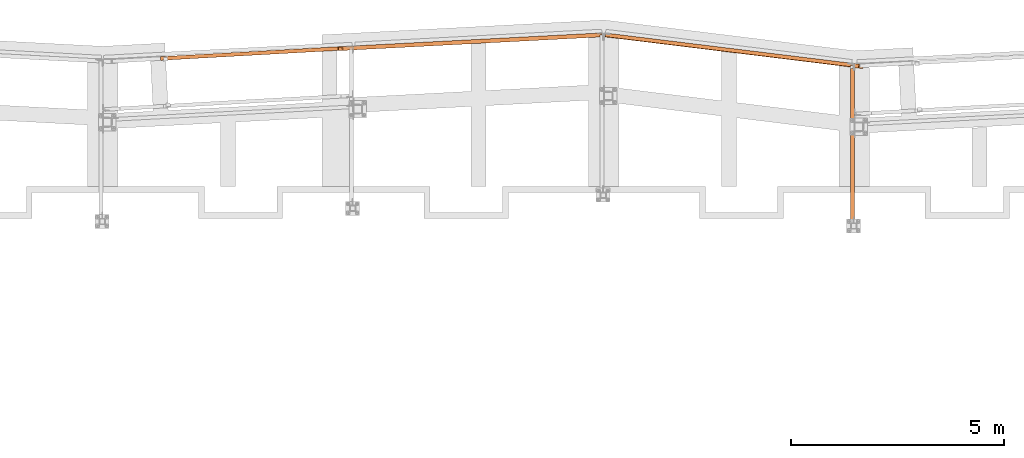
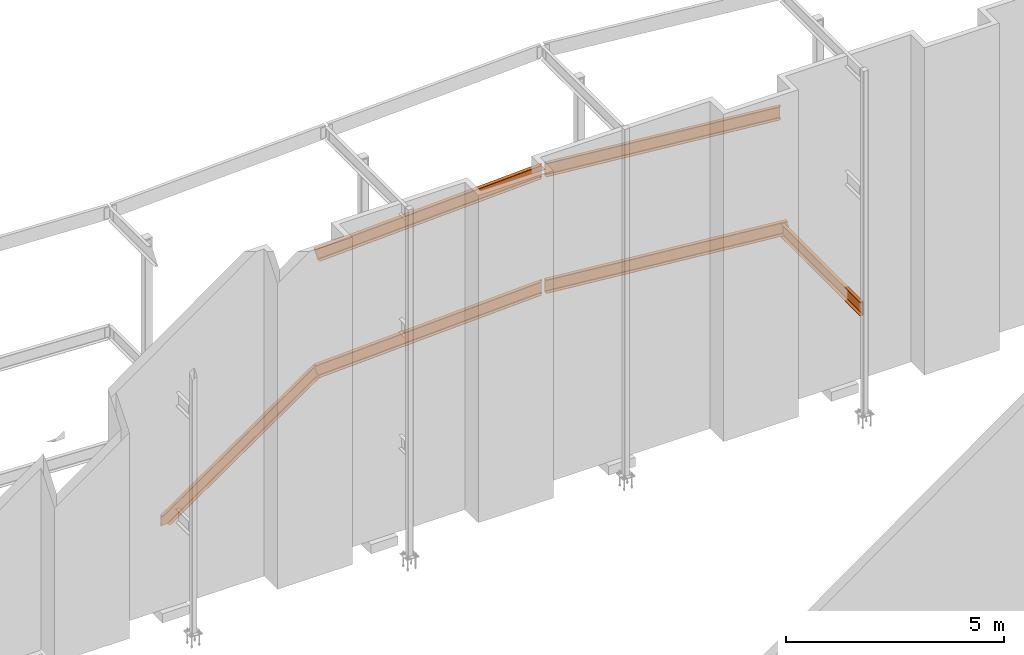
# One storey, part 17 of 89: 6 proxies.
"""IFC4 building model written with IfcOpenShell, lengths in feet."""

from ifc_helpers import new_model, entity, si_unit, converted_unit, derived_unit, direction, frame, origin, place, context, subcontext, project, spatial, faceted_brep, source, transform, mapped, material, constituent, constituent_set, type_object, type_shapes, element, save


model = new_model("IFC4")

# Units and contexts
model_context = context("Model", 3, precision=0.0001, world=origin(), true_north=direction((6.12303176911189e-17, 1.0)))
body_context = subcontext(model_context, "Body", "Model", "MODEL_VIEW")
ifc_project = project(units=[converted_unit("LENGTHUNIT", "FOOT", entity("IfcRatioMeasure", 0.3048), si_unit("LENGTHUNIT", "METRE"), dimensions=[1, 0, 0, 0, 0, 0, 0]), converted_unit("AREAUNIT", "SQUARE FOOT", entity("IfcRatioMeasure", 0.09290304), si_unit("AREAUNIT", "SQUARE_METRE"), dimensions=[2, 0, 0, 0, 0, 0, 0]), converted_unit("VOLUMEUNIT", "CUBIC FOOT", entity("IfcRatioMeasure", 0.028316846592), si_unit("VOLUMEUNIT", "CUBIC_METRE"), dimensions=[3, 0, 0, 0, 0, 0, 0]), si_unit("PLANEANGLEUNIT", "RADIAN"), si_unit("MASSUNIT", "GRAM", prefix="KILO"), derived_unit("MASSDENSITYUNIT", [(si_unit("MASSUNIT", "GRAM", prefix="KILO"), 1), (si_unit("LENGTHUNIT", "METRE"), -3)]), derived_unit("MOMENTOFINERTIAUNIT", [(si_unit("LENGTHUNIT", "METRE"), 4)]), si_unit("TIMEUNIT", "SECOND"), si_unit("FREQUENCYUNIT", "HERTZ"), si_unit("THERMODYNAMICTEMPERATUREUNIT", "DEGREE_CELSIUS"), derived_unit("THERMALTRANSMITTANCEUNIT", [(si_unit("MASSUNIT", "GRAM", prefix="KILO"), 1), (si_unit("THERMODYNAMICTEMPERATUREUNIT", "KELVIN"), -1), (si_unit("TIMEUNIT", "SECOND"), -3)]), derived_unit("VOLUMETRICFLOWRATEUNIT", [(si_unit("LENGTHUNIT", "METRE"), 3), (si_unit("TIMEUNIT", "SECOND"), -1)]), si_unit("ELECTRICCURRENTUNIT", "AMPERE"), si_unit("ELECTRICVOLTAGEUNIT", "VOLT"), si_unit("POWERUNIT", "WATT"), si_unit("FORCEUNIT", "NEWTON"), si_unit("ILLUMINANCEUNIT", "LUX"), si_unit("LUMINOUSFLUXUNIT", "LUMEN"), si_unit("LUMINOUSINTENSITYUNIT", "CANDELA"), derived_unit("USERDEFINED", [(si_unit("MASSUNIT", "GRAM", prefix="KILO"), -1), (si_unit("LENGTHUNIT", "METRE"), -2), (si_unit("TIMEUNIT", "SECOND"), 3), (si_unit("LUMINOUSFLUXUNIT", "LUMEN"), 1)]), derived_unit("LINEARVELOCITYUNIT", [(si_unit("LENGTHUNIT", "METRE"), 1), (si_unit("TIMEUNIT", "SECOND"), -1)]), si_unit("PRESSUREUNIT", "PASCAL"), derived_unit("USERDEFINED", [(si_unit("LENGTHUNIT", "METRE"), -2), (si_unit("MASSUNIT", "GRAM", prefix="KILO"), 1), (si_unit("TIMEUNIT", "SECOND"), -2)]), derived_unit("LINEARFORCEUNIT", [(si_unit("MASSUNIT", "GRAM", prefix="KILO"), 1), (si_unit("LENGTHUNIT", "METRE"), 1), (si_unit("TIMEUNIT", "SECOND"), -2), (si_unit("LENGTHUNIT", "METRE"), -1)]), derived_unit("PLANARFORCEUNIT", [(si_unit("MASSUNIT", "GRAM", prefix="KILO"), 1), (si_unit("LENGTHUNIT", "METRE"), 1), (si_unit("TIMEUNIT", "SECOND"), -2), (si_unit("LENGTHUNIT", "METRE"), -2)])], contexts=[model_context])

# Site, building, storey
site_placement = place(None, origin())
site = spatial("IfcSite", under=ifc_project, at=site_placement, CompositionType="ELEMENT")
building_placement = place(site_placement, frame((-472.238160486, -49.138065117, 0.0)))
building = spatial("IfcBuilding", under=site, at=building_placement, CompositionType="ELEMENT")
storey_placement = place(building_placement, origin())
storey = spatial("IfcBuildingStorey", under=building, at=storey_placement, Name="Level 1", CompositionType="ELEMENT", Elevation=0.0)

# Proxies
ifc_material_1 = material(Name="Color 7720", Category="Materials")
ifc_material_2 = material()
ifc_constituent_1 = constituent(ifc_material_2)
ifc_constituent_2 = constituent(ifc_material_1, Name="Color 7720", Category="Materials")
ifc_constituent_set_1 = constituent_set(constituents=[ifc_constituent_1, ifc_constituent_2])
building_element_proxy_type_1 = type_object("IfcBuildingElementProxyType", Name="21B1", PredefinedType="NOTDEFINED", material=ifc_constituent_set_1)
shared_shape_1 = source(origin(), body_context, "Body", "Brep", [
    faceted_brep([(0.0377794964555278, 2.75073335405659, 1.25), (0.0377794964555278, 2.75073335405659, 0.0), (0.0, 2.44304404704769, 0.0), (0.0, 2.44304404704769, 0.0333062789934004), (0.0251267470594598, 2.64768497970852, 0.0676680457191203), (0.0272486596628596, 2.66496657104051, 0.0738437414016904), (0.0289818227031446, 2.67908205125684, 0.0856354543123796), (0.0301143991183039, 2.68830614593799, 0.10160193411237), (0.0305079589656998, 2.69151143367526, 0.11979166666667), (0.0305079589656998, 2.69151143367526, 1.13020833333333), (0.0301143991183039, 2.68830614593799, 1.14839806588763), (0.0289818227031446, 2.67908205125684, 1.16436454568762), (0.0272486596628596, 2.66496657104051, 1.17615625859831), (0.0251267470594598, 2.64768497970852, 1.18233195428088), (0.0, 2.44304404704769, 1.2166937210066), (0.0, 2.44304404704769, 1.25), (19.5543690065045, 0.0420694348507595, 1.24999999999986), (19.5634983388827, 0.0409484937833895, 1.21669372100646), (19.5980437300844, 0.244432962358815, 1.18233195428074), (19.6018584159503, 0.261506707269177, 1.17615625859818), (19.6068237162849, 0.275225330927015, 1.16436454568747), (19.61233274379, 0.283912064982815, 1.1483980658875), (19.6177121537347, 0.286505167305222, 1.1302083333332), (19.8946698286601, 0.252499040800672, 0.119791666666796), (19.89926211891, 0.248681567648418, 0.101601934112518), (19.9025059935848, 0.23892011234193, 0.0856354543125466), (19.9040049678388, 0.224407775567101, 0.0738437414018609), (19.9035758284979, 0.206918337813363, 0.0676680457192891), (19.8878677255806, 0.00112094106725635, 0.0333062789935603), (19.8969970579588, 0.0, 0.0), (19.9347765544144, 0.307689307008786, 0.0), (19.5921485029601, 0.349758741859659, 1.24999999999986)], [[[0, 1, 2, 3, 4, 5, 6, 7, 8, 9, 10, 11, 12, 13, 14, 15]], [[16, 17, 18, 19, 20, 21, 22, 23, 24, 25, 26, 27, 28, 29, 30, 31]], [[30, 1, 0, 31]], [[29, 2, 1, 30]], [[28, 3, 2, 29]], [[27, 4, 3, 28]], [[26, 5, 4, 27]], [[25, 6, 5, 26]], [[24, 7, 6, 25]], [[23, 8, 7, 24]], [[22, 9, 8, 23]], [[21, 10, 9, 22]], [[20, 11, 10, 21]], [[19, 12, 11, 20]], [[18, 13, 12, 19]], [[17, 14, 13, 18]], [[16, 15, 14, 17]], [[31, 0, 15, 16]]]),
])
type_shapes(building_element_proxy_type_1, [shared_shape_1])
proxy_1_placement = place(building_placement, frame((269.262655882732, 1017.10742242747, 8.35416666666667)))
element("IfcBuildingElementProxy", 1, at=proxy_1_placement, inside=storey, type_object=building_element_proxy_type_1, material=ifc_material_1, Name="21B1:21B1", ObjectType="21B1:21B1", PredefinedType="NOTDEFINED", context=body_context, shape_type="MappedRepresentation", body=[
    mapped(shared_shape_1, transform((0.0, 0.0, 0.0), scale=1.0)),
])
ifc_constituent_3 = constituent(ifc_material_2)
ifc_constituent_4 = constituent(ifc_material_1, Name="Color 7720", Category="Materials")
ifc_constituent_set_2 = constituent_set(constituents=[ifc_constituent_3, ifc_constituent_4])
building_element_proxy_type_2 = type_object("IfcBuildingElementProxyType", Name="22B1", PredefinedType="NOTDEFINED", material=ifc_constituent_set_2)
shared_shape_2 = source(origin(), body_context, "Body", "Brep", [
    faceted_brep([(0.0, 0.309575155773928, 1.25000000000001), (0.357523018910911, 0.328312143237667, 0.0), (0.373747165346231, 0.0187369874637398, 0.0), (0.364220956214695, 0.0182377399981988, 0.0333062789934182), (0.343602348434359, 0.223617862109791, 0.0676680457191399), (0.340924744883978, 0.240912802348703, 0.0738437414017064), (0.336807802828474, 0.254938044365076, 0.0856354543123956), (0.331754718383394, 0.263979343166739, 0.10160193411239), (0.326383108321096, 0.266931619698767, 0.119791666666686), (0.0373853347014972, 0.2517858881655, 1.13020833333334), (0.0323517478101962, 0.248288298368379, 1.14839806588764), (0.0282714177601235, 0.238768337595616, 1.16436454568763), (0.0256430657389046, 0.224389589695988, 1.17615625859832), (0.0247879439063752, 0.206909507165051, 1.18233195428089), (0.0257503555669132, 0.000499247465540975, 1.2166937210066), (0.016224146435377, 0.0, 1.25000000000001), (20.3463952666531, 1.22985108098965, 0.0), (20.338762939701, 1.37548455480794, 0.0), (20.338762939701, 1.37548455480794, 1.25), (20.3463952666531, 1.22985108098965, 1.25), (20.3463952666531, 1.22985108098965, 1.18933355874539), (20.3441965764159, 1.27180458993962, 1.18233195428088), (20.343285335557, 1.2891921013246, 1.17615625859831), (20.3425410405399, 1.30339409628266, 1.16436454568762), (20.3420546633424, 1.31267472606976, 1.14839806588763), (20.3418856517569, 1.31589965923422, 1.13020833333333), (20.3418856517569, 1.31589965923422, 0.11979166666667), (20.3420546633424, 1.31267472606976, 0.10160193411237), (20.3425410405399, 1.30339409628266, 0.0856354543123796), (20.343285335557, 1.2891921013246, 0.0738437414016904), (20.3441965764159, 1.27180458993962, 0.0676680457191203), (20.3463952666531, 1.22985108098965, 0.0606664412546092), (20.2162116682723, 1.21985240890331, 0.0), (20.2031852629111, 1.21012513065352, 0.0), (20.1948729018438, 1.19615330785678, 0.0), (20.1925400666913, 1.18006402387846, 0.0), (20.198951221331, 1.05773190587115, 0.0), (20.2319689657958, 1.22385425267009, 0.0), (20.198951221331, 1.05773190587115, 0.0333062789934004), (20.1948729018436, 1.1961533078611, 0.0563796692854748), (20.2031852629109, 1.21012513065784, 0.0586325310785618), (20.2162116682721, 1.21985240890763, 0.0601378452028776), (20.2319689657956, 1.22385425267441, 0.0606664412286193), (20.192540066691, 1.18006402388278, 0.0537222376092839), (20.2162116682723, 1.21985240890331, 1.18986215477137), (20.2031852629111, 1.21012513065352, 1.19136746889581), (20.1948729018438, 1.19615330785678, 1.19362033068901), (20.1925400666913, 1.18006402387846, 1.19627776236529), (20.198951221331, 1.05773190587126, 1.21669372100739), (20.2319689657958, 1.22385425267009, 1.1893335587455), (20.198951221331, 1.05773190587115, 1.25), (20.1948729018438, 1.19615330785678, 1.25), (20.2031852629111, 1.21012513065352, 1.25), (20.2162116682723, 1.21985240890331, 1.25), (20.2319689657958, 1.22385425267009, 1.25), (20.1925400666913, 1.18006402387846, 1.25)], [[[0, 1, 2, 3, 4, 5, 6, 7, 8, 9, 10, 11, 12, 13, 14, 15]], [[16, 17, 18, 19, 20, 21, 22, 23, 24, 25, 26, 27, 28, 29, 30, 31]], [[17, 1, 0, 18]], [[32, 33, 34, 35, 36, 2, 1, 17, 16, 37]], [[38, 3, 2, 36]], [[39, 40, 41, 42, 31, 30, 4, 3, 38, 43]], [[29, 5, 4, 30]], [[28, 6, 5, 29]], [[27, 7, 6, 28]], [[26, 8, 7, 27]], [[25, 9, 8, 26]], [[24, 10, 9, 25]], [[23, 11, 10, 24]], [[22, 12, 11, 23]], [[21, 13, 12, 22]], [[44, 45, 46, 47, 48, 14, 13, 21, 20, 49]], [[50, 15, 14, 48]], [[51, 52, 53, 54, 19, 18, 0, 15, 50, 55]], [[19, 54, 49, 20]], [[53, 44, 49, 54]], [[52, 45, 44, 53]], [[51, 46, 45, 52]], [[55, 47, 46, 51]], [[48, 47, 55, 50]], [[42, 37, 16, 31]], [[32, 37, 42, 41]], [[33, 32, 41, 40]], [[34, 33, 40, 39]], [[35, 34, 39, 43]], [[35, 43, 38, 36]]]),
])
type_shapes(building_element_proxy_type_2, [shared_shape_2])
proxy_2_placement = place(building_placement, frame((248.665914336964, 1018.49083804157, 8.35416666666667)))
element("IfcBuildingElementProxy", 2, at=proxy_2_placement, inside=storey, type_object=building_element_proxy_type_2, material=ifc_material_1, Name="22B1:22B1", ObjectType="22B1:22B1", PredefinedType="NOTDEFINED", context=body_context, shape_type="MappedRepresentation", body=[
    mapped(shared_shape_2, transform((0.0, 0.0, 0.0), scale=1.0)),
])
ifc_constituent_5 = constituent(ifc_material_2)
ifc_constituent_6 = constituent(ifc_material_1, Name="Color 7720", Category="Materials")
ifc_constituent_set_3 = constituent_set(constituents=[ifc_constituent_5, ifc_constituent_6])
building_element_proxy_type_3 = type_object("IfcBuildingElementProxyType", Name="16B1", PredefinedType="NOTDEFINED", material=ifc_constituent_set_3)
shared_shape_3 = source(origin(), body_context, "Body", "Brep", [
    faceted_brep([(0.0345296472984273, 2.6011820874744, 1.25), (0.0345296472984273, 2.6011820874744, 0.0), (0.0, 2.3199606778428, 0.0), (0.0, 2.3199606778428, 0.033334055807881), (0.0250827848585686, 2.52424356710685, 0.0676357025785492), (0.0272060141263637, 2.54153588181021, 0.0738152303316895), (0.028940252608777, 2.55566012079942, 0.0856142600983709), (0.0300735317970293, 2.56488993910807, 0.101590647231951), (0.030467335851597, 2.56809721575314, 0.119791666666671), (0.030467335851597, 2.56809721575314, 1.13020833333333), (0.0300735317970293, 2.56488993910807, 1.14840935276805), (0.028940252608777, 2.55566012079942, 1.16438573990164), (0.0272060141263637, 2.54153588181021, 1.17618476966831), (0.0250827848585686, 2.52424356710685, 1.18236429742145), (0.0, 2.3199606778428, 1.21666594419212), (0.0, 2.3199606778428, 1.25), (19.0600584689071, 0.0657378988789787, 0.0), (19.0841784431227, 0.262179324724571, 0.0), (19.0841784431227, 0.262179324724571, 1.25), (19.0600584689071, 0.0657378988789787, 1.25), (19.0600584689071, 0.0657378988789787, 1.20243032677195), (19.0747315806829, 0.185240804357022, 1.18236429742145), (19.0768548099507, 0.202533119060263, 1.17618476966831), (19.0785890484331, 0.216657358049474, 1.16438573990164), (19.0797223276214, 0.225887176358356, 1.14840935276805), (19.0801161316759, 0.229094453003199, 1.13020833333333), (19.0801161316759, 0.229094453003199, 0.119791666666671), (19.0797223276214, 0.225887176358356, 0.101590647231951), (19.0785890484331, 0.216657358049474, 0.0856142600983709), (19.0768548099507, 0.202533119060263, 0.0738152303316895), (19.0747315806829, 0.185240804357022, 0.0676357025785492), (19.0600584689071, 0.0657378988789787, 0.0475696732280504), (18.9301164007198, 0.0784972737093312, 0.0), (18.9155987715845, 0.0711797862259118, 0.0), (18.9049865123923, 0.0588636531633711, 0.0), (18.8998952434047, 0.043423894134321, 0.0), (18.8945634596307, 0.0, 0.0), (18.946329222365, 0.0797020944773976, 0.0), (18.8945634596307, 0.0, 0.033334055807881), (18.9049865123923, 0.0588636531639395, 0.0432829012814437), (18.9155987715846, 0.0711797862264802, 0.0455357630745894), (18.9301164007198, 0.0784972737098997, 0.0470410771989549), (18.946329222365, 0.0797020944779661, 0.0475696732248103), (18.8998952434047, 0.0434238941348895, 0.0406254696052635), (18.9301164007198, 0.0784972737094449, 1.20295892279827), (18.9155987715845, 0.0711797862260255, 1.20446423692263), (18.9049865123923, 0.0588636531634847, 1.20671709871575), (18.8998952434047, 0.0434238941344347, 1.2093745303919), (18.8945634596307, 0.0, 1.2166659441924), (18.946329222365, 0.0797020944775113, 1.20243032677241), (18.8945634596307, 0.0, 1.25), (18.9049865123923, 0.0588636531633711, 1.25), (18.9155987715845, 0.0711797862259118, 1.25), (18.9301164007198, 0.0784972737093312, 1.25), (18.946329222365, 0.0797020944773976, 1.25), (18.8998952434047, 0.043423894134321, 1.25)], [[[0, 1, 2, 3, 4, 5, 6, 7, 8, 9, 10, 11, 12, 13, 14, 15]], [[16, 17, 18, 19, 20, 21, 22, 23, 24, 25, 26, 27, 28, 29, 30, 31]], [[17, 1, 0, 18]], [[32, 33, 34, 35, 36, 2, 1, 17, 16, 37]], [[38, 3, 2, 36]], [[39, 40, 41, 42, 31, 30, 4, 3, 38, 43]], [[29, 5, 4, 30]], [[28, 6, 5, 29]], [[27, 7, 6, 28]], [[26, 8, 7, 27]], [[25, 9, 8, 26]], [[24, 10, 9, 25]], [[23, 11, 10, 24]], [[22, 12, 11, 23]], [[21, 13, 12, 22]], [[44, 45, 46, 47, 48, 14, 13, 21, 20, 49]], [[50, 15, 14, 48]], [[51, 52, 53, 54, 19, 18, 0, 15, 50, 55]], [[19, 54, 49, 20]], [[53, 44, 49, 54]], [[52, 45, 44, 53]], [[51, 46, 45, 52]], [[55, 47, 46, 51]], [[48, 47, 55, 50]], [[42, 37, 16, 31]], [[32, 37, 42, 41]], [[33, 32, 41, 40]], [[34, 33, 40, 39]], [[35, 34, 39, 43]], [[35, 43, 38, 36]]]),
])
type_shapes(building_element_proxy_type_3, [shared_shape_3])
proxy_3_placement = place(building_placement, frame((269.266544310737, 1017.25731477227, 19.0208333333333)))
element("IfcBuildingElementProxy", 3, at=proxy_3_placement, inside=storey, type_object=building_element_proxy_type_3, material=ifc_material_1, Name="16B1:16B1", ObjectType="16B1:16B1", PredefinedType="NOTDEFINED", context=body_context, shape_type="MappedRepresentation", body=[
    mapped(shared_shape_3, transform((0.0, 0.0, 0.0), scale=1.0)),
])
ifc_constituent_7 = constituent(ifc_material_2)
ifc_constituent_8 = constituent(ifc_material_1, Name="Color 7720", Category="Materials")
ifc_constituent_set_4 = constituent_set(constituents=[ifc_constituent_7, ifc_constituent_8])
building_element_proxy_type_4 = type_object("IfcBuildingElementProxyType", Name="30B1", PredefinedType="NOTDEFINED", material=ifc_constituent_set_4)
shared_shape_4 = source(origin(), body_context, "Body", "Brep", [
    faceted_brep([(0.0, 0.309575155773928, 1.25), (0.349557129762729, 0.327894668677345, 0.0), (0.365781276198021, 0.0183195129034175, 0.0), (0.356467318367606, 0.0178313890572781, 0.0333062789933933), (0.336067688207038, 0.223222987299664, 0.0676680457191239), (0.333429440582421, 0.240519990095095, 0.0738437414016886), (0.329387643709254, 0.25454917030379, 0.0856354543123743), (0.324436309030716, 0.263595801584756, 0.101601934112363), (0.31918061688296, 0.266554153116999, 0.119791666666671), (0.0366219369913949, 0.251745880186945, 1.13020833333333), (0.0317042680146358, 0.248254365390039, 1.14839806588762), (0.0277256877310776, 0.238739737096694, 1.16436454568763), (0.0251724808921665, 0.224364927389388, 1.1761562585983), (0.02435671498543, 0.206886907414969, 1.18233195428089), (0.0255381042656779, 0.000488123846253075, 1.2166937210066), (0.0162241464352633, 0.0, 1.24999999999999), (20.3463952666532, 1.22985108098953, 0.0), (20.338762939701, 1.37548455480783, 0.0), (20.338762939701, 1.37548455480783, 1.25), (20.3463952666532, 1.22985108098953, 1.25), (20.3463952666532, 1.22985108098953, 1.18933355874539), (20.344196576416, 1.27180458993951, 1.18233195428088), (20.343285335557, 1.28919210132449, 1.17615625859831), (20.3425410405399, 1.30339409628255, 1.16436454568762), (20.3420546633424, 1.31267472606964, 1.14839806588763), (20.3418856517569, 1.31589965923411, 1.13020833333333), (20.3418856517569, 1.31589965923411, 0.119791666666671), (20.3420546633424, 1.31267472606964, 0.10160193411237), (20.3425410405399, 1.30339409628255, 0.0856354543123814), (20.343285335557, 1.28919210132449, 0.0738437414016886), (20.344196576416, 1.27180458993951, 0.0676680457191203), (20.3463952666532, 1.22985108098953, 0.060666441254611), (20.2058092772852, 1.21930724269214, 0.0), (20.192782871924, 1.2095799644427, 0.0), (20.1844705108568, 1.19560814164572, 0.0), (20.1821376757042, 1.17951885766763, 0.0), (20.1885488303439, 1.0571867396601, 0.0), (20.2215665748087, 1.22330908645915, 0.0), (20.1885488303439, 1.0571867396601, 0.0333062789934004), (20.1844705108569, 1.19560814164208, 0.0563796693330865), (20.1927828719242, 1.20957996443906, 0.0586325311263209), (20.2058092772854, 1.2193072426885, 0.0601378452507468), (20.2215665748089, 1.22330908645552, 0.060666441276723), (20.1821376757044, 1.17951885766399, 0.0537222376568991), (20.2058092772852, 1.21930724269214, 1.18986215477156), (20.192782871924, 1.2095799644427, 1.19136746889583), (20.1844705108568, 1.19560814164572, 1.1936203306889), (20.1821376757042, 1.17951885766763, 1.19627776236494), (20.1885488303439, 1.05718673965987, 1.21669372100557), (20.2215665748087, 1.22330908645915, 1.1893335587457), (20.1885488303439, 1.0571867396601, 1.25), (20.1844705108568, 1.19560814164572, 1.25), (20.192782871924, 1.2095799644427, 1.25), (20.2058092772852, 1.21930724269214, 1.25), (20.2215665748087, 1.22330908645915, 1.25), (20.1821376757042, 1.17951885766763, 1.25)], [[[0, 1, 2, 3, 4, 5, 6, 7, 8, 9, 10, 11, 12, 13, 14, 15]], [[16, 17, 18, 19, 20, 21, 22, 23, 24, 25, 26, 27, 28, 29, 30, 31]], [[17, 1, 0, 18]], [[32, 33, 34, 35, 36, 2, 1, 17, 16, 37]], [[38, 3, 2, 36]], [[39, 40, 41, 42, 31, 30, 4, 3, 38, 43]], [[29, 5, 4, 30]], [[28, 6, 5, 29]], [[27, 7, 6, 28]], [[26, 8, 7, 27]], [[25, 9, 8, 26]], [[24, 10, 9, 25]], [[23, 11, 10, 24]], [[22, 12, 11, 23]], [[21, 13, 12, 22]], [[44, 45, 46, 47, 48, 14, 13, 21, 20, 49]], [[50, 15, 14, 48]], [[51, 52, 53, 54, 19, 18, 0, 15, 50, 55]], [[19, 54, 49, 20]], [[53, 44, 49, 54]], [[52, 45, 44, 53]], [[51, 46, 45, 52]], [[55, 47, 46, 51]], [[48, 47, 55, 50]], [[42, 37, 16, 31]], [[32, 37, 42, 41]], [[33, 32, 41, 40]], [[34, 33, 40, 39]], [[35, 34, 39, 43]], [[35, 43, 38, 36]]]),
])
type_shapes(building_element_proxy_type_4, [shared_shape_4])
proxy_4_placement = place(building_placement, frame((248.666666666667, 1018.49106536893, 19.0208333333333)))
element("IfcBuildingElementProxy", 4, at=proxy_4_placement, inside=storey, type_object=building_element_proxy_type_4, material=ifc_material_1, Name="30B1:30B1", ObjectType="30B1:30B1", PredefinedType="NOTDEFINED", context=body_context, shape_type="MappedRepresentation", body=[
    mapped(shared_shape_4, transform((0.0, 0.0, 0.0), scale=1.0)),
])
ifc_constituent_9 = constituent(ifc_material_2)
ifc_constituent_10 = constituent(ifc_material_1, Name="Color 7720", Category="Materials")
ifc_constituent_set_5 = constituent_set(constituents=[ifc_constituent_9, ifc_constituent_10])
building_element_proxy_type_5 = type_object("IfcBuildingElementProxyType", Name="c775", PredefinedType="NOTDEFINED", material=ifc_constituent_set_5)
shared_shape_5 = source(origin(), body_context, "Body", "Brep", [
    faceted_brep([(0.0, 0.0, 1.25), (0.0, 0.0, 1.21666594419212), (0.205817018106814, 0.0, 1.18236429742145), (0.22323919507528, 0.0, 1.17618476966831), (0.237469504634078, 0.0, 1.16438573990164), (0.246768637267337, 0.0, 1.14840935276805), (0.25, 0.0, 1.13020833333334), (0.25, 0.0, 0.119791666666673), (0.246768637267337, 0.0, 0.101590647231953), (0.237469504634078, 0.0, 0.0856142600983727), (0.22323919507528, 0.0, 0.073815230331693), (0.205817018106814, 0.0, 0.0676357025785528), (0.0, 0.0, 0.0333340558078827), (0.0, 0.0, 0.0), (0.28333333333336, 0.0, 0.0), (0.28333333333336, 0.0, 1.25), (0.25, 12.0372040033701, 1.125), (0.28333333333336, 12.0372040033701, 1.125), (0.28333333333336, 12.0372040033701, 0.125000000000004), (0.25, 12.0372040033701, 0.125000000000004), (0.0, 11.8913706700368, 1.21666594419212), (0.0, 11.8913706700368, 1.25), (0.205817018106814, 11.8913706700368, 1.18236429742145), (0.208250000000021, 11.8913706700368, 1.18150133528077), (0.22323919507528, 11.8913706700368, 1.17618476966832), (0.234718575567058, 11.8913706700368, 1.16666666666667), (0.237469504634078, 11.8918243745794, 1.16438573990162), (0.245422827132927, 11.8945423561822, 1.15072152365148), (0.246768637267337, 11.8960872993737, 1.14840935276807), (0.248758027692929, 11.9035745541541, 1.13720388411723), (0.249999999999943, 11.9140441357703, 1.13020833333334), (0.250000000000057, 11.9170921936882, 0.121828313854644), (0.250000000000057, 11.9140441357703, 0.119791666666673), (0.250000000000057, 11.9170921936882, 1.12817168614537), (0.250000000000057, 11.9330373367035, 1.125), (0.250000000000057, 11.9330373367035, 0.125000000000004), (0.248758027692986, 11.9035745541541, 0.11279611588277), (0.246768637267337, 11.8960872993737, 0.101590647231946), (0.245422827132927, 11.8945423561822, 0.099278476348525), (0.237469504634078, 11.8918243745794, 0.0856142600983567), (0.234718575567058, 11.8913706700368, 0.0833333333332948), (0.22323919507528, 11.8913706700368, 0.0738152303316735), (0.205817018106814, 11.8913706700368, 0.0676357025785528), (0.208250000000021, 11.8913706700368, 0.0684986647192289), (0.0, 11.8913706700368, 0.0333340558078827), (0.0, 11.8913706700368, 0.0), (0.208250000000021, 11.8913706700368, 0.0), (0.28333333333336, 11.8913706700368, 0.0), (0.28333333333336, 11.8945423561822, 0.0992784763485535), (0.28333333333336, 11.9035745541541, 0.112796115882773), (0.28333333333336, 11.9170921936882, 0.121828313854644), (0.28333333333336, 11.9330373367035, 0.125000000000004), (0.28333333333336, 11.9330373367035, 1.125), (0.28333333333336, 11.9170921936882, 1.12817168614537), (0.28333333333336, 11.9035745541541, 1.13720388411723), (0.28333333333336, 11.8945423561822, 1.15072152365146), (0.28333333333336, 11.8913706700368, 1.16666666666667), (0.28333333333336, 11.8913706700368, 1.25), (0.28333333333336, 11.8913706700368, 0.0833333333333339), (0.208250000000021, 11.8913706700368, 1.25000000000001)], [[[0, 1, 2, 3, 4, 5, 6, 7, 8, 9, 10, 11, 12, 13, 14, 15]], [[16, 17, 18, 19]], [[20, 1, 0, 21]], [[22, 2, 1, 20]], [[23, 24, 3, 2, 22]], [[4, 3, 24, 25, 26]], [[5, 4, 26, 27, 28]], [[6, 5, 28, 29, 30]], [[31, 32, 7, 6, 30, 33, 34, 16, 19, 35]], [[8, 7, 32, 36, 37]], [[9, 8, 37, 38, 39]], [[10, 9, 39, 40, 41]], [[42, 11, 10, 41, 43]], [[44, 12, 11, 42]], [[45, 13, 12, 44]], [[46, 47, 14, 13, 45]], [[48, 49, 50, 51, 18, 17, 52, 53, 54, 55, 56, 57, 15, 14, 47, 58]], [[21, 0, 15, 57, 59]], [[57, 56, 25, 24, 23, 22, 20, 21, 59]], [[56, 55, 27, 26, 25]], [[55, 54, 29, 28, 27]], [[54, 53, 33, 30, 29]], [[53, 52, 34, 33]], [[34, 52, 17, 16]], [[51, 35, 19, 18]], [[31, 35, 51, 50]], [[50, 49, 36, 32, 31]], [[49, 48, 38, 37, 36]], [[48, 58, 40, 39, 38]], [[44, 45, 46, 47, 58, 40, 41, 43, 42]]]),
])
type_shapes(building_element_proxy_type_5, [shared_shape_5])
proxy_5_placement = place(building_placement, frame((288.216666666667, 1005.234375, 8.35416666666666)))
element("IfcBuildingElementProxy", 5, at=proxy_5_placement, inside=storey, type_object=building_element_proxy_type_5, material=ifc_material_1, Name="c775:c775", ObjectType="c775:c775", PredefinedType="NOTDEFINED", context=body_context, shape_type="MappedRepresentation", body=[
    mapped(shared_shape_5, transform((0.0, 0.0, 0.0), scale=1.0)),
])
ifc_constituent_11 = constituent(ifc_material_2)
ifc_constituent_12 = constituent(ifc_material_1, Name="Color 7720", Category="Materials")
ifc_constituent_set_6 = constituent_set(constituents=[ifc_constituent_11, ifc_constituent_12])
building_element_proxy_type_6 = type_object("IfcBuildingElementProxyType", Name="c644", PredefinedType="NOTDEFINED", material=ifc_constituent_set_6)
shared_shape_6 = source(origin(), body_context, "Body", "Brep", [
    faceted_brep([(0.0, 0.28289351553849, 2.09684312651839e-07), (0.707232670482568, 0.322345690372117, 0.0), (0.723013565370763, 0.0394521748326042, 0.0), (0.660145009996199, 0.0359451235583492, 1.8639637590427e-08), (0.583988115515439, 0.237833801498596, 3.78203124752864e-08), (0.571363060839303, 0.25457879052567, 4.12757591938544e-08), (0.548317314991777, 0.267545643236417, 4.78734993963683e-08), (0.517667660340436, 0.275149477009677, 5.68071196826665e-08), (0.483160272312432, 0.276460907956448, 6.6984702079359e-08), (0.0018565758704483, 0.249611925475051, 2.09684312651839e-07), (13.7015000332583, 1.04721620219675, 9.58515138815906), (13.7172809281465, 0.764322686657238, 9.58515138815906), (13.7245293535905, 0.764727031874486, 9.55980424557848), (13.7235209223413, 0.89032544334043, 9.53889503357595), (13.7147277861083, 1.04795409743247, 9.53889503357594), (13.7370165405717, 1.04919745039751, 9.46095310788649), (13.7388731164409, 1.01591586033408, 9.46095310788649), (14.0207298768161, 1.03163892100781, 8.47532339455758), (14.0188733009469, 1.06492051107125, 8.47532339455758), (14.0724546909928, 0.784135653411909, 8.34313819823145), (14.0566737961046, 1.06702916895142, 8.34313819823145), (14.053810122229, 1.0668694221423, 8.35315222825615), (14.0695910171172, 0.783975906602791, 8.35315222825615), (0.0, 0.282893515534738, 1.03139765914799), (13.6935325870147, 1.04677174721212, 9.58958625447322), (13.6572987822074, 1.044750485382, 9.50309329352723), (13.6450838005692, 1.04406908644319, 9.49144497836936), (13.6384898801841, 1.04370125205048, 9.47589704478434), (13.6386008209928, 1.04370744075823, 9.45900500580774), (13.645398388374, 1.04408663536844, 9.44354529636365), (13.6577653102503, 1.04477651012178, 9.43205892865758), (13.6736689158562, 1.04566367477798, 9.42643384247553), (13.6904952326521, 1.04660231183448, 9.427594596762), (13.7054786280424, 1.04743814360415, 9.43535040586082), (13.9149863618574, 1.05912529564569, 8.41661291406196), (13.9025318187381, 1.05843053304056, 8.40582773665139), (13.8952300553684, 1.05802321242732, 8.3910481313531), (13.8942247103872, 1.05796713039445, 8.37458895374797), (13.8996732459454, 1.05827107078983, 8.35902812241833), (13.9107222851976, 1.05888742895127, 8.34680285246704), (13.925641272445, 1.05971966778554, 8.33982792671847), (13.9420935214096, 1.06063743789105, 8.33919579287127), (13.9575021987077, 1.06149699353114, 8.34500545888512), (14.0096819822677, 1.06440778375577, 8.37771497966132), (14.0463278360466, 0.782678196351299, 8.36610105714486), (13.9498290571908, 0.921967677564908, 8.33919579287213), (13.9302823054604, 0.976522982495567, 8.33982792671933), (13.928914050496, 0.98226540527321, 8.34031633068941), (14.0184728680423, 0.906819472113853, 8.37771497966218), (13.9663209213777, 0.903409668539325, 8.34500545888598), (13.9212764506934, 0.999288613831254, 8.3434333953656), (13.9136206491555, 1.00693040273916, 8.34680285246705), (13.9097917789863, 1.0129003879905, 8.35065884596251), (13.9018675341183, 1.0189355388228, 8.35902812241837), (13.9000622346621, 1.02167122646335, 8.36373351247463), (13.8961502692465, 1.0234489285466, 8.37458895374797), (13.8966034907881, 1.02471467091675, 8.38313831470355), (13.8970866312378, 1.02474162236012, 8.3910481313531), (13.9043883946075, 1.02514894297337, 8.40582773665139), (13.9168429377268, 1.0258437055785, 8.41661291406196), (13.7073352039114, 1.01415655354469, 9.43535040586082), (13.692351808521, 1.01332072177502, 9.427594596762), (13.6755254917252, 1.01238208471864, 9.42643384247553), (13.6657809546871, 1.01183849673839, 9.42988047351012), (0.00185657589116772, 0.249611925476302, 0.890196426087744), (13.6596724531486, 1.01058843885266, 9.4320589286576), (13.6498736667377, 1.0077147400973, 9.44128021493226), (0.00203655399346303, 0.246385578781542, 0.911650392449944), (13.647539159118, 1.00571047444532, 9.44354529636369), (13.6427645212824, 0.998004574355377, 9.45534517913231), (0.00255449035086031, 0.237100881174456, 0.930482132802942), (13.6414211958641, 0.993148472578127, 9.45900500580781), (13.6418874492378, 0.983703214298657, 9.46820946524987), (0.00334707983111571, 0.222892661297919, 0.944389924541149), (13.6428101742198, 0.966305424041593, 9.47546364299848), (0.00431744763159259, 0.205497528741716, 0.951673878114351), (13.6429307115698, 0.964093447074447, 9.47589704478423), (13.6527644111074, 0.906383934110295, 9.49144497836933), (13.6661175086921, 0.886663092016988, 9.50309329352724), (0.0157808949100229, 0.0, 0.992106029655536), (13.7093134819026, 0.763878231677495, 9.58958625447322), (0.015780894910165, 0.0, 1.03139765914799)], [[[0, 1, 2, 3, 4, 5, 6, 7, 8, 9]], [[10, 11, 12, 13, 14]], [[15, 16, 17, 18]], [[19, 20, 21, 22]], [[23, 24, 10, 14, 25, 26, 27, 28, 29, 30, 31, 32, 33, 15, 18, 34, 35, 36, 37, 38, 39, 40, 41, 42, 43, 21, 20, 1, 0]], [[2, 1, 20, 19]], [[44, 3, 2, 19, 22]], [[45, 46, 47, 4, 3, 44, 48, 49]], [[5, 4, 47, 50]], [[6, 5, 50, 51, 52]], [[7, 6, 52, 53, 54]], [[8, 7, 54, 55, 56]], [[9, 8, 56, 57, 58, 59, 17, 16, 60, 61, 62, 63, 64]], [[64, 63, 65, 66, 67]], [[67, 66, 68, 69, 70]], [[70, 69, 71, 72, 73]], [[73, 72, 74, 75]], [[75, 74, 76, 77, 78, 13, 12, 79]], [[79, 12, 11, 80, 81]], [[81, 80, 24, 23]], [[80, 11, 10, 24]], [[78, 25, 14, 13]], [[26, 25, 78, 77]], [[27, 26, 77, 76]], [[72, 71, 28, 27, 76, 74]], [[29, 28, 71, 69, 68]], [[30, 29, 68, 66, 65]], [[31, 30, 65, 63, 62]], [[62, 61, 32, 31]], [[61, 60, 33, 32]], [[60, 16, 15, 33]], [[59, 34, 18, 17]], [[35, 34, 59, 58]], [[36, 35, 58, 57]], [[37, 36, 57, 56, 55]], [[38, 37, 55, 54, 53]], [[39, 38, 53, 52, 51]], [[46, 40, 39, 51, 50, 47]], [[41, 40, 46, 45]], [[45, 49, 42, 41]], [[43, 42, 49, 48]], [[48, 44, 22, 21, 43]], [[64, 9, 0, 23, 81, 79, 75, 73, 70, 67]]]),
])
type_shapes(building_element_proxy_type_6, [shared_shape_6])
proxy_6_placement = place(building_placement, frame((234.949813388171, 1017.74921514933, -6.989706520244e-07)))
element("IfcBuildingElementProxy", 6, at=proxy_6_placement, inside=storey, type_object=building_element_proxy_type_6, material=ifc_material_1, PredefinedType="NOTDEFINED", context=body_context, shape_type="MappedRepresentation", body=[
    mapped(shared_shape_6, transform((0.0, 0.0, 0.0), scale=1.0)),
])

save(model, "model.ifc")
